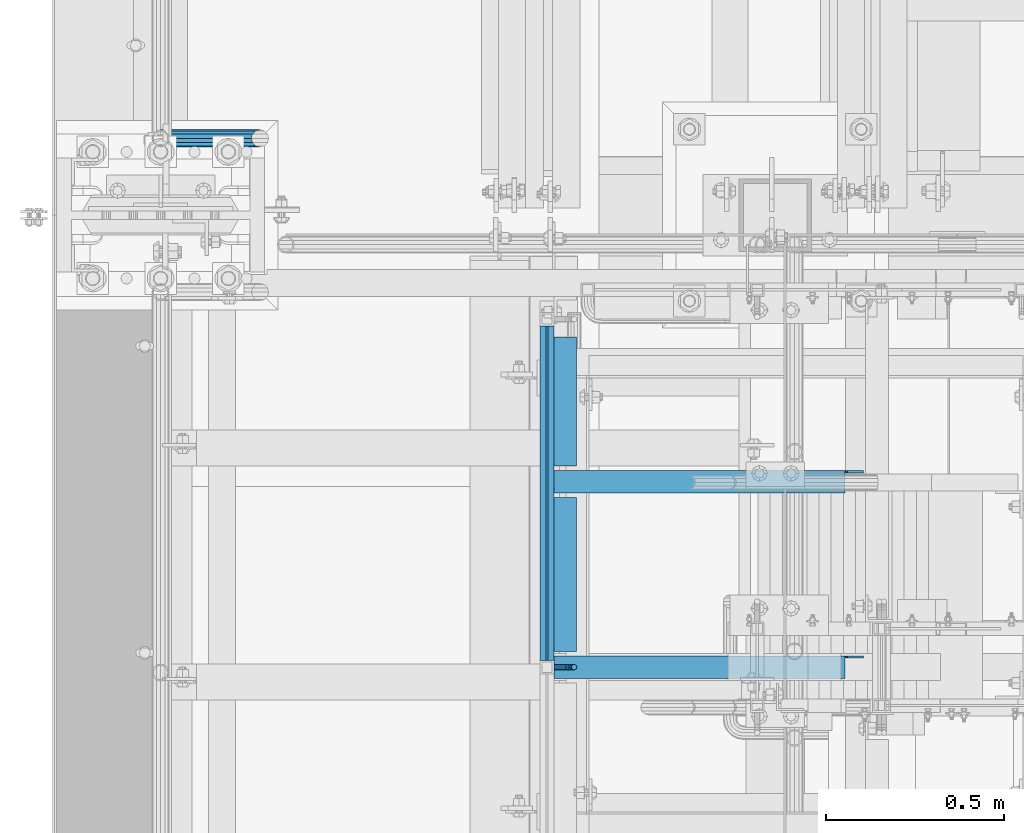
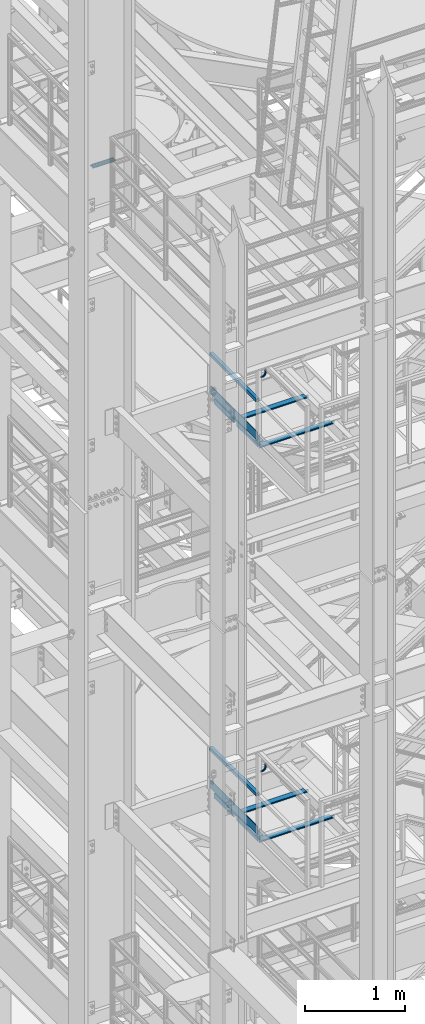
# One storey, part 1157 of 1876: 15 beams, 5 elements without a shape of their own.
"""IFC2X3 building model written with IfcOpenShell, lengths in millimetres."""

from ifc_helpers import new_model, si_unit, frame, origin_with_axes, place, context, subcontext, project, spatial, faceted_brep, material, type_object, element, aggregate, save


model = new_model("IFC2X3")

# Units and contexts
model_context = context("Model", 3, precision=1e-05, world=origin_with_axes())
body_context = subcontext(model_context, "Body", "Model", "MODEL_VIEW")
ifc_project = project(units=[si_unit("LENGTHUNIT", "METRE", prefix="MILLI"), si_unit("AREAUNIT", "SQUARE_METRE"), si_unit("VOLUMEUNIT", "CUBIC_METRE"), si_unit("MASSUNIT", "GRAM", prefix="KILO"), si_unit("TIMEUNIT", "SECOND"), si_unit("PLANEANGLEUNIT", "RADIAN"), si_unit("SOLIDANGLEUNIT", "STERADIAN"), si_unit("THERMODYNAMICTEMPERATUREUNIT", "DEGREE_CELSIUS"), si_unit("LUMINOUSINTENSITYUNIT", "LUMEN")], contexts=[model_context])

# Site, building, storey
site_placement = place(None, origin_with_axes())
site = spatial("IfcSite", under=ifc_project, at=site_placement, CompositionType="ELEMENT")
building_placement = place(site_placement, origin_with_axes())
building = spatial("IfcBuilding", under=site, at=building_placement, Name="Undefined", CompositionType="ELEMENT")
storey_placement = place(building_placement, origin_with_axes())
storey = spatial("IfcBuildingStorey", under=building, at=storey_placement, Name="Undefined", CompositionType="ELEMENT", Elevation=0.0)

# Assembly, beam
assembly_1_placement = place(storey_placement, origin_with_axes())
assembly_1 = element("IfcElementAssembly", 1, at=assembly_1_placement, inside=storey, Name="RAIL", AssemblyPlace="NOTDEFINED", PredefinedType="RIGID_FRAME")
ifc_material_1 = material()
beam_type_1 = type_object("IfcBeamType", Name="PIPE1-1/2SCH40", PredefinedType="NOTDEFINED")
beam_1_placement = place(assembly_1_placement, frame((-1.00044417195022e-11, -4356.1, 18449.925000036), z_axis=(0.0, 0.0, 1.0), x_axis=(1.0, 0.0, 0.0)))
beam_1 = element("IfcBeam", 2, at=beam_1_placement, type_object=beam_type_1, material=ifc_material_1, Name="RAIL", ObjectType="PIPE1-1/2SCH40", context=body_context, shape_type="Brep", body=[
    faceted_brep([(258.502800903171, -12.0650000000005, 20.8971929933177), (258.502800903171, -12.0650000000005, 15.8661214311796), (258.009372465309, -10.2235000000001, 17.7076214311819), (255.26999389649, 0.0, 20.4470000000001), (255.26999389649, 0.0, 24.130000000001), (258.009372465309, 10.2235000000001, 17.7076214311819), (258.502800903171, 12.0650000000005, 15.8661214311796), (258.502800903171, 12.0650000000005, 20.8971929933177), (279.399993896489, 24.1299999999992, 0.0), (267.33499389649, 20.8971929933177, 12.0649999999987), (267.33499389649, 20.8971929933177, -12.0649999999987), (264.145422334351, 17.7076214311801, 10.2235000000001), (266.884800903171, 20.4470000000001, 0.0), (264.145422334351, 17.7076214311801, -10.2235000000001), (258.502800903171, 12.0650000000005, -15.8661214311796), (258.502800903171, 12.0650000000005, -20.8971929933177), (258.009372465309, 10.2235000000001, -17.7076214311819), (255.26999389649, 0.0, -20.4470000000001), (255.26999389649, 0.0, -24.130000000001), (258.502800903171, -12.0650000000005, -15.8661214311796), (258.502800903171, -12.0650000000005, -20.8971929933177), (258.009372465309, -10.2235000000001, -17.7076214311819), (279.399993896489, -24.1299999999992, 0.0), (267.33499389649, -20.8971929933177, -12.0649999999987), (267.33499389649, -20.8971929933177, 12.0649999999987), (264.145422334351, -17.7076214311801, -10.2235000000001), (266.884800903171, -20.4470000000001, 0.0), (264.145422334351, -17.7076214311801, 10.2235000000001), (12.0650000000064, -20.8971929933177, -12.0649999999987), (20.8971929933249, -12.0650000000005, -20.8971929933177), (0.0, 24.1299999999992, 0.0), (12.0650000000064, 20.8971929933177, -12.0649999999987), (12.0650000000064, 20.8971929933177, 12.0649999999987), (20.8971929933249, 12.0650000000005, 20.8971929933177), (24.1300000000064, 0.0, 24.130000000001), (20.8971929933249, 12.0650000000005, -20.8971929933177), (24.1300000000063, 0.0, -24.130000000001), (24.1300000000063, 0.0, -20.4470000000001), (20.8971929933249, -12.0650000000005, -15.8661214311796), (21.3906214311868, -10.2235000000001, -17.7076214311819), (21.3906214311868, 10.2235000000001, -17.7076214311819), (20.8971929933249, 12.0650000000005, -15.8661214311796), (15.2545715621445, 17.7076214311801, -10.2235000000001), (12.5151929933249, 20.4470000000001, 0.0), (15.2545715621445, 17.7076214311801, 10.2235000000001), (20.8971929933249, 12.0650000000005, 15.8661214311796), (21.3906214311868, 10.2235000000001, 17.7076214311819), (24.1300000000064, 0.0, 20.4470000000001), (21.3906214311868, -10.2235000000001, 17.7076214311819), (20.8971929933249, -12.0650000000005, 15.8661214311796), (20.8971929933249, -12.0650000000005, 20.8971929933177), (12.0650000000064, -20.8971929933177, 12.0649999999987), (0.0, -24.1299999999992, 0.0), (15.2545715621445, -17.7076214311801, 10.2235000000001), (12.5151929933249, -20.4470000000001, 0.0), (15.2545715621445, -17.7076214311801, -10.2235000000001)], [[[0, 1, 2, 3, 4]], [[4, 3, 5, 6, 7]], [[8, 9, 10]], [[7, 6, 11, 12, 13, 14, 15, 10, 9]], [[16, 17, 18, 15, 14]], [[19, 20, 18, 17, 21]], [[22, 23, 24]], [[24, 23, 20, 19, 25, 26, 27, 1, 0]], [[28, 29, 20, 23]], [[30, 31, 32]], [[33, 34, 4, 7]], [[32, 33, 7, 9]], [[30, 32, 9, 8]], [[31, 30, 8, 10]], [[35, 31, 10, 15]], [[36, 35, 15, 18]], [[29, 36, 18, 20]], [[37, 36, 29, 38, 39]], [[40, 41, 35, 36, 37]], [[32, 31, 35, 41, 42, 43, 44, 45, 33]], [[33, 45, 46, 47, 34]], [[34, 47, 48, 49, 50]], [[34, 50, 0, 4]], [[50, 51, 24, 0]], [[51, 52, 22, 24]], [[52, 28, 23, 22]], [[51, 28, 52]], [[50, 49, 53, 54, 55, 38, 29, 28, 51]], [[55, 54, 26, 25]], [[21, 39, 38, 55, 25, 19]], [[37, 39, 21, 17]], [[40, 37, 17, 16]], [[42, 41, 40, 16, 14, 13]], [[43, 42, 13, 12]], [[44, 43, 12, 11]], [[5, 46, 45, 44, 11, 6]], [[47, 46, 5, 3]], [[48, 47, 3, 2]], [[53, 49, 48, 2, 1, 27]], [[54, 53, 27, 26]]]),
])
aggregate(assembly_1, [beam_1])

# Assembly, beams
assembly_2_placement = place(storey_placement, origin_with_axes())
assembly_2 = element("IfcElementAssembly", 3, at=assembly_2_placement, inside=storey, Name="STRINGER", AssemblyPlace="NOTDEFINED", PredefinedType="RIGID_FRAME")
ifc_material_2 = material(Name="STEEL/A36")
beam_type_2 = type_object("IfcBeamType", Name="L2-1/2X2-1/2X1/4", PredefinedType="NOTDEFINED")
beam_2_placement = place(assembly_2_placement, frame((1136.65000017493, -5797.55000149109, 15531.2768517499), z_axis=(1.0, 0.0, 0.0), x_axis=(0.0, 1.0, 0.0)))
beam_2 = element("IfcBeam", 4, at=beam_2_placement, type_object=beam_type_2, material=ifc_material_2, Name="ANGLE", ObjectType="L2-1/2X2-1/2X1/4", context=body_context, shape_type="Brep", body=[
    faceted_brep([(0.0, 31.75, -31.75), (0.0, 31.75, 31.75), (431.800000762049, 31.75, 31.75), (431.800000762049, 31.75, -31.75), (0.0, 25.3999999999996, 31.75), (431.800000762049, 25.3999999999996, 31.75), (0.0, 25.3999999999996, -25.3999999999996), (431.800000762049, 25.3999999999996, -25.4000000000001), (0.0, -31.75, -25.3999999999996), (431.800000762049, -31.75, -25.4000000000001), (0.0, -31.75, -31.75), (431.800000762049, -31.75, -31.75)], [[[0, 1, 2, 3]], [[1, 4, 5, 2]], [[4, 6, 7, 5]], [[6, 8, 9, 7]], [[8, 10, 11, 9]], [[10, 0, 3, 11]], [[5, 7, 9, 11, 3, 2]], [[10, 8, 6, 4, 1, 0]]]),
])
beam_3_placement = place(assembly_2_placement, frame((1136.64999999374, -5276.85000132472, 15531.2768517499), z_axis=(1.0, 0.0, 0.0), x_axis=(0.0, 1.0, 0.0)))
beam_3 = element("IfcBeam", 5, at=beam_3_placement, type_object=beam_type_2, material=ifc_material_2, Name="ANGLE", ObjectType="L2-1/2X2-1/2X1/4", context=body_context, shape_type="Brep", body=[
    faceted_brep([(0.0, 31.75, -31.75), (0.0, 31.75, 31.75), (361.950002661927, 31.75, 31.7499999999923), (361.950002661926, 31.75, -31.7500000000077), (0.0, 25.3999999999996, 31.75), (361.950002661927, 25.3999999999996, 31.7499999999923), (0.0, 25.3999999999996, -25.3999999999996), (361.950002661926, 25.3999999999996, -25.4000000000076), (0.0, -31.75, -25.3999999999996), (361.950002661926, -31.75, -25.4000000000076), (0.0, -31.75, -31.75), (361.950002661926, -31.75, -31.7500000000077)], [[[0, 1, 2, 3]], [[1, 4, 5, 2]], [[4, 6, 7, 5]], [[6, 8, 9, 7]], [[8, 10, 11, 9]], [[10, 0, 3, 11]], [[5, 7, 9, 11, 3, 2]], [[10, 8, 6, 4, 1, 0]]]),
])

assembly_3_placement = place(storey_placement, origin_with_axes())
assembly_3 = element("IfcElementAssembly", 6, at=assembly_3_placement, inside=storey, Name="STRINGER", AssemblyPlace="NOTDEFINED", PredefinedType="RIGID_FRAME")
beam_4_placement = place(assembly_3_placement, frame((1136.65000052344, -5797.55000149059, 10702.925), z_axis=(1.0, 0.0, 0.0), x_axis=(0.0, 1.0, 0.0)))
beam_4 = element("IfcBeam", 7, at=beam_4_placement, type_object=beam_type_2, material=ifc_material_2, Name="ANGLE", ObjectType="L2-1/2X2-1/2X1/4", context=body_context, shape_type="Brep", body=[
    faceted_brep([(0.0, 31.75, -31.75), (0.0, 31.75, 31.75), (431.800000762049, 31.75, 31.75), (431.800000762049, 31.75, -31.75), (0.0, 25.3999999999996, 31.75), (431.800000762049, 25.3999999999996, 31.75), (0.0, 25.3999999999996, -25.3999999999996), (431.800000762049, 25.3999999999996, -25.4000000000001), (0.0, -31.75, -25.3999999999996), (431.800000762049, -31.75, -25.4000000000001), (0.0, -31.75, -31.75), (431.800000762049, -31.75, -31.75)], [[[0, 1, 2, 3]], [[1, 4, 5, 2]], [[4, 6, 7, 5]], [[6, 8, 9, 7]], [[8, 10, 11, 9]], [[10, 0, 3, 11]], [[5, 7, 9, 11, 3, 2]], [[10, 8, 6, 4, 1, 0]]]),
])
beam_5_placement = place(assembly_3_placement, frame((1136.65000034225, -5276.85000132422, 10702.925), z_axis=(1.0, 0.0, 0.0), x_axis=(0.0, 1.0, 0.0)))
beam_5 = element("IfcBeam", 8, at=beam_5_placement, type_object=beam_type_2, material=ifc_material_2, Name="ANGLE", ObjectType="L2-1/2X2-1/2X1/4", context=body_context, shape_type="Brep", body=[
    faceted_brep([(0.0, 31.75, -31.75), (0.0, 31.75, 31.75), (361.950002661927, 31.75, 31.7499999999923), (361.950002661926, 31.75, -31.7500000000077), (0.0, 25.3999999999996, 31.75), (361.950002661927, 25.3999999999996, 31.7499999999923), (0.0, 25.3999999999996, -25.3999999999996), (361.950002661926, 25.3999999999996, -25.4000000000076), (0.0, -31.75, -25.3999999999996), (361.950002661926, -31.75, -25.4000000000076), (0.0, -31.75, -31.75), (361.950002661926, -31.75, -31.7500000000077)], [[[0, 1, 2, 3]], [[1, 4, 5, 2]], [[4, 6, 7, 5]], [[6, 8, 9, 7]], [[8, 10, 11, 9]], [[10, 0, 3, 11]], [[5, 7, 9, 11, 3, 2]], [[10, 8, 6, 4, 1, 0]]]),
])

# Beam
beam_6_placement = place(assembly_2_placement, frame((1104.90000017493, -5842.0000011457, 15531.3367794488), z_axis=(0.0, -1.0, 0.0), x_axis=(1.0, 0.0, 0.0)))
beam_6 = element("IfcBeam", 9, at=beam_6_placement, type_object=beam_type_2, material=ifc_material_2, Name="STRINGER", ObjectType="L2-1/2X2-1/2X1/4", context=body_context, shape_type="Brep", body=[
    faceted_brep([(0.0, -31.75, -31.75), (0.0, -31.75, -25.3999999999996), (0.0, 25.3999999999996, -25.3999999999996), (0.0, 25.3999999999996, 31.75), (0.0, 31.75, 31.75), (0.0, 31.75, -31.75), (869.950004852295, 6.34999909336329, -25.3999999999996), (830.262999809266, 6.34999909336329, -25.3999999999996), (825.40292029122, 7.31672901595084, -25.3999999999996), (821.282743823066, 10.0697429164284, -25.3999999999996), (818.529729922588, 14.189919384582, -25.3999999999996), (817.563000000001, 19.0499989026284, -25.3999999999996), (817.563000000001, 25.3999999999996, -25.3999999999996), (869.949999999999, -31.75, -25.3999999999996), (869.950004852295, -19.0499986178183, -25.3999999999996), (817.563000000001, 25.3999999999996, 31.75), (817.563000000001, 31.75, 31.75), (817.563000000001, 31.75, -31.75), (817.563000000001, 19.0499989026284, -31.75), (818.529729922588, 14.189919384582, -31.75), (821.282743823066, 10.0697429164284, -31.75), (825.40292029122, 7.31672901595084, -31.75), (830.262999809266, 6.34999909336329, -31.75), (869.950004852295, 6.34999909336329, -31.75), (869.950004852295, -19.0499986178183, -31.75), (869.949999999999, -31.75, -31.75)], [[[0, 1, 2, 3, 4, 5]], [[6, 7, 8, 9, 10, 11, 12, 2, 1, 13, 14]], [[3, 2, 12, 15]], [[4, 3, 15, 16]], [[5, 4, 16, 17]], [[15, 12, 11, 18, 17, 16]], [[10, 19, 18, 11]], [[9, 20, 19, 10]], [[8, 21, 20, 9]], [[7, 22, 21, 8]], [[6, 23, 22, 7]], [[14, 24, 23, 6]], [[0, 5, 17, 18, 19, 20, 21, 22, 23, 24, 25]], [[1, 0, 25, 13]], [[24, 14, 13, 25]]]),
])

beam_7_placement = place(assembly_2_placement, frame((1104.89999999374, -5321.30000114659, 15531.3367793052), z_axis=(0.0, -1.0, 0.0), x_axis=(1.0, 0.0, 0.0)))
beam_7 = element("IfcBeam", 10, at=beam_7_placement, type_object=beam_type_2, material=ifc_material_2, Name="STRINGER", ObjectType="L2-1/2X2-1/2X1/4", context=body_context, shape_type="Brep", body=[
    faceted_brep([(0.0, -31.75, -31.75), (0.0, -31.75, -25.3999999999996), (0.0, 25.3999999999996, -25.3999999999996), (0.0, 25.3999999999996, 31.75), (0.0, 31.75, 31.75), (0.0, 31.75, -31.75), (869.950004852295, 6.34999909336329, -25.3999999999996), (830.262999809266, 6.34999909336329, -25.3999999999996), (825.40292029122, 7.31672901595084, -25.3999999999996), (821.282743823066, 10.0697429164284, -25.3999999999996), (818.529729922588, 14.189919384582, -25.3999999999996), (817.563000000001, 19.0499989026284, -25.3999999999996), (817.563000000001, 25.3999999999996, -25.3999999999996), (869.949999999999, -31.75, -25.3999999999996), (869.950004852295, -19.0499986178183, -25.3999999999996), (817.563000000001, 25.3999999999996, 31.75), (817.563000000001, 31.75, 31.75), (817.563000000001, 31.75, -31.75), (817.563000000001, 19.0499989026284, -31.75), (818.529729922588, 14.189919384582, -31.75), (821.282743823066, 10.0697429164284, -31.75), (825.40292029122, 7.31672901595084, -31.75), (830.262999809266, 6.34999909336329, -31.75), (869.950004852295, 6.34999909336329, -31.75), (869.950004852295, -19.0499986178183, -31.75), (869.949999999999, -31.75, -31.75)], [[[0, 1, 2, 3, 4, 5]], [[6, 7, 8, 9, 10, 11, 12, 2, 1, 13, 14]], [[3, 2, 12, 15]], [[4, 3, 15, 16]], [[5, 4, 16, 17]], [[15, 12, 11, 18, 17, 16]], [[10, 19, 18, 11]], [[9, 20, 19, 10]], [[8, 21, 20, 9]], [[7, 22, 21, 8]], [[6, 23, 22, 7]], [[14, 24, 23, 6]], [[0, 5, 17, 18, 19, 20, 21, 22, 23, 24, 25]], [[1, 0, 25, 13]], [[24, 14, 13, 25]]]),
])

aggregate(assembly_2, [beam_2, beam_3, beam_6, beam_7])

beam_8_placement = place(assembly_3_placement, frame((1104.90000052344, -5842.00000114519, 10702.9250002874), z_axis=(0.0, -1.0, 0.0), x_axis=(1.0, 0.0, 0.0)))
beam_8 = element("IfcBeam", 11, at=beam_8_placement, type_object=beam_type_2, material=ifc_material_2, Name="STRINGER", ObjectType="L2-1/2X2-1/2X1/4", context=body_context, shape_type="Brep", body=[
    faceted_brep([(0.0, -31.75, -31.75), (0.0, -31.75, -25.3999999999996), (0.0, 25.3999999999996, -25.3999999999996), (0.0, 25.3999999999996, 31.75), (0.0, 31.75, 31.75), (0.0, 31.75, -31.75), (869.950004852295, 6.34999909336329, -25.3999999999996), (830.262999809266, 6.34999909336329, -25.3999999999996), (825.40292029122, 7.31672901595084, -25.3999999999996), (821.282743823066, 10.0697429164284, -25.3999999999996), (818.529729922588, 14.189919384582, -25.3999999999996), (817.563000000001, 19.0499989026284, -25.3999999999996), (817.563000000001, 25.3999999999996, -25.3999999999996), (869.949999999999, -31.75, -25.3999999999996), (869.950004852295, -19.0499986178183, -25.3999999999996), (817.563000000001, 25.3999999999996, 31.75), (817.563000000001, 31.75, 31.75), (817.563000000001, 31.75, -31.75), (817.563000000001, 19.0499989026284, -31.75), (818.529729922588, 14.189919384582, -31.75), (821.282743823066, 10.0697429164284, -31.75), (825.40292029122, 7.31672901595084, -31.75), (830.262999809266, 6.34999909336329, -31.75), (869.950004852295, 6.34999909336329, -31.75), (869.950004852295, -19.0499986178183, -31.75), (869.949999999999, -31.75, -31.75)], [[[0, 1, 2, 3, 4, 5]], [[6, 7, 8, 9, 10, 11, 12, 2, 1, 13, 14]], [[3, 2, 12, 15]], [[4, 3, 15, 16]], [[5, 4, 16, 17]], [[15, 12, 11, 18, 17, 16]], [[10, 19, 18, 11]], [[9, 20, 19, 10]], [[8, 21, 20, 9]], [[7, 22, 21, 8]], [[6, 23, 22, 7]], [[14, 24, 23, 6]], [[0, 5, 17, 18, 19, 20, 21, 22, 23, 24, 25]], [[1, 0, 25, 13]], [[24, 14, 13, 25]]]),
])

beam_9_placement = place(assembly_3_placement, frame((1104.90000034225, -5321.30000114608, 10702.9250001437), z_axis=(0.0, -1.0, 0.0), x_axis=(1.0, 0.0, 0.0)))
beam_9 = element("IfcBeam", 12, at=beam_9_placement, type_object=beam_type_2, material=ifc_material_2, Name="STRINGER", ObjectType="L2-1/2X2-1/2X1/4", context=body_context, shape_type="Brep", body=[
    faceted_brep([(0.0, -31.75, -31.75), (0.0, -31.75, -25.3999999999996), (0.0, 25.3999999999996, -25.3999999999996), (0.0, 25.3999999999996, 31.75), (0.0, 31.75, 31.75), (0.0, 31.75, -31.75), (869.950004852295, 6.34999909336329, -25.3999999999996), (830.262999809266, 6.34999909336329, -25.3999999999996), (825.40292029122, 7.31672901595084, -25.3999999999996), (821.282743823066, 10.0697429164284, -25.3999999999996), (818.529729922588, 14.189919384582, -25.3999999999996), (817.563000000001, 19.0499989026284, -25.3999999999996), (817.563000000001, 25.3999999999996, -25.3999999999996), (869.949999999999, -31.75, -25.3999999999996), (869.950004852295, -19.0499986178183, -25.3999999999996), (817.563000000001, 25.3999999999996, 31.75), (817.563000000001, 31.75, 31.75), (817.563000000001, 31.75, -31.75), (817.563000000001, 19.0499989026284, -31.75), (818.529729922588, 14.189919384582, -31.75), (821.282743823066, 10.0697429164284, -31.75), (825.40292029122, 7.31672901595084, -31.75), (830.262999809266, 6.34999909336329, -31.75), (869.950004852295, 6.34999909336329, -31.75), (869.950004852295, -19.0499986178183, -31.75), (869.949999999999, -31.75, -31.75)], [[[0, 1, 2, 3, 4, 5]], [[6, 7, 8, 9, 10, 11, 12, 2, 1, 13, 14]], [[3, 2, 12, 15]], [[4, 3, 15, 16]], [[5, 4, 16, 17]], [[15, 12, 11, 18, 17, 16]], [[10, 19, 18, 11]], [[9, 20, 19, 10]], [[8, 21, 20, 9]], [[7, 22, 21, 8]], [[6, 23, 22, 7]], [[14, 24, 23, 6]], [[0, 5, 17, 18, 19, 20, 21, 22, 23, 24, 25]], [[1, 0, 25, 13]], [[24, 14, 13, 25]]]),
])

aggregate(assembly_3, [beam_4, beam_5, beam_8, beam_9])

# Assembly, beam
assembly_4_placement = place(storey_placement, origin_with_axes())
assembly_4 = element("IfcElementAssembly", 13, at=assembly_4_placement, inside=storey, Name="RAIL", AssemblyPlace="NOTDEFINED", PredefinedType="RIGID_FRAME")
beam_type_3 = type_object("IfcBeamType", PredefinedType="NOTDEFINED")
beam_10_placement = place(assembly_4_placement, frame((1085.85000037624, -5842.000001149, 15658.2768517481), z_axis=(0.0, 0.0, 1.0), x_axis=(0.0, 1.0, 0.0)))
beam_10 = element("IfcBeam", 14, at=beam_10_placement, type_object=beam_type_3, material=ifc_material_2, Name="PLATE", context=body_context, shape_type="Brep", body=[
    faceted_brep([(19.049997819523, 3.17500000000018, -50.7999999999975), (19.049997413123, 3.17500000000018, 50.8000000000011), (958.85000076813, 3.17499999999995, 50.7999999999993), (958.85000076813, 3.17499999999995, -50.7999999999993), (19.049997413123, -3.17500000000018, 50.8000000000011), (958.85000076813, -3.17499999999995, 50.7999999999993), (19.049997819523, -3.17500000000018, -50.7999999999975), (958.85000076813, -3.17499999999995, -50.7999999999993)], [[[0, 1, 2, 3]], [[1, 4, 5, 2]], [[4, 6, 7, 5]], [[6, 0, 3, 7]], [[5, 7, 3, 2]], [[6, 4, 1, 0]]]),
])

# Assembly, beams
assembly_5_placement = place(storey_placement, origin_with_axes())
assembly_5 = element("IfcElementAssembly", 15, at=assembly_5_placement, inside=storey, Name="RAIL", AssemblyPlace="NOTDEFINED", PredefinedType="RIGID_FRAME")
beam_11_placement = place(assembly_5_placement, frame((1085.85000225475, -5842.00000114849, 10829.9249999981), z_axis=(0.0, 0.0, 1.0), x_axis=(0.0, 1.0, 0.0)))
beam_11 = element("IfcBeam", 16, at=beam_11_placement, type_object=beam_type_3, material=ifc_material_2, Name="PLATE", context=body_context, shape_type="Brep", body=[
    faceted_brep([(19.049997819523, 3.17500000000018, -50.7999999999975), (19.049997413123, 3.17500000000018, 50.8000000000011), (958.85000076813, 3.17499999999995, 50.7999999999993), (958.85000076813, 3.17499999999995, -50.7999999999993), (19.049997413123, -3.17500000000018, 50.8000000000011), (958.85000076813, -3.17499999999995, 50.7999999999993), (19.049997819523, -3.17500000000018, -50.7999999999975), (958.85000076813, -3.17499999999995, -50.7999999999993)], [[[0, 1, 2, 3]], [[1, 4, 5, 2]], [[4, 6, 7, 5]], [[6, 0, 3, 7]], [[5, 7, 3, 2]], [[6, 4, 1, 0]]]),
])
ifc_material_3 = material()
beam_type_4 = type_object("IfcBeamType", Name="HSS1-1/2X1-1/2X1/8", PredefinedType="NOTDEFINED")
beam_12_placement = place(assembly_5_placement, frame((1085.85000034225, -4864.10000114536, 11274.4249999981), z_axis=(0.0, 0.0, 1.0), x_axis=(0.0, -1.0, 0.0)))
beam_12 = element("IfcBeam", 17, at=beam_12_placement, type_object=beam_type_4, material=ifc_material_3, Name="RAIL", ObjectType="HSS1-1/2X1-1/2X1/8", context=body_context, shape_type="Brep", body=[
    faceted_brep([(958.850000766446, -19.0499992350001, 19.0499992349996), (958.850000766446, -19.0499992350001, -19.0499992349996), (958.850000766446, 19.0499992350001, -19.0499992349996), (958.850000766446, 19.0499992350001, 19.0499992349996), (958.850000766446, -15.8749992830001, 15.8749992829999), (958.850000766446, 15.8749992830001, 15.8749992829999), (958.850000766446, 15.8749992830001, -15.8749992829999), (958.850000766446, -15.8749992830001, -15.8749992829999), (19.0500000000002, 19.0499992349996, 19.0499992350001), (19.0500000000002, -19.0499992349996, 19.0499992350001), (19.0500000000002, -19.0499992349996, -19.0499992350001), (19.0500000000002, 19.0499992349996, -19.0499992350001), (19.0500000000002, -15.8749992829999, 15.8749992829999), (19.0500000000002, -15.8749992829999, -15.8749992829999), (19.0500000000002, 15.8749992829999, -15.8749992829999), (19.0500000000002, 15.8749992829999, 15.8749992829999)], [[[0, 1, 2, 3], [4, 5, 6, 7]], [[0, 3, 8, 9]], [[2, 1, 10, 11]], [[1, 0, 9, 10]], [[3, 2, 11, 8]], [[9, 8, 11, 10], [12, 13, 14, 15]], [[4, 7, 13, 12]], [[7, 6, 14, 13]], [[6, 5, 15, 14]], [[5, 4, 12, 15]]]),
])

# Beam
beam_13_placement = place(assembly_4_placement, frame((1085.84999999374, -4864.10000114587, 16102.776851748), z_axis=(0.0, 0.0, 1.0), x_axis=(0.0, -1.0, 0.0)))
beam_13 = element("IfcBeam", 18, at=beam_13_placement, type_object=beam_type_4, material=ifc_material_3, Name="RAIL", ObjectType="HSS1-1/2X1-1/2X1/8", context=body_context, shape_type="Brep", body=[
    faceted_brep([(958.850000766446, -19.0499992350001, 19.0499992349996), (958.850000766446, -19.0499992350001, -19.0499992349996), (958.850000766446, 19.0499992350001, -19.0499992349996), (958.850000766446, 19.0499992350001, 19.0499992349996), (958.850000766446, -15.8749992830001, 15.8749992829999), (958.850000766446, 15.8749992830001, 15.8749992829999), (958.850000766446, 15.8749992830001, -15.8749992829999), (958.850000766446, -15.8749992830001, -15.8749992829999), (19.0500000000002, 19.0499992349996, 19.0499992350001), (19.0500000000002, -19.0499992349996, 19.0499992350001), (19.0500000000002, -19.0499992349996, -19.0499992350001), (19.0500000000002, 19.0499992349996, -19.0499992350001), (19.0500000000002, -15.8749992829999, 15.8749992829999), (19.0500000000002, -15.8749992829999, -15.8749992829999), (19.0500000000002, 15.8749992829999, -15.8749992829999), (19.0500000000002, 15.8749992829999, 15.8749992829999)], [[[0, 1, 2, 3], [4, 5, 6, 7]], [[0, 3, 8, 9]], [[2, 1, 10, 11]], [[1, 0, 9, 10]], [[3, 2, 11, 8]], [[9, 8, 11, 10], [12, 13, 14, 15]], [[4, 7, 13, 12]], [[7, 6, 14, 13]], [[6, 5, 15, 14]], [[5, 4, 12, 15]]]),
])

beam_type_5 = type_object("IfcBeamType", PredefinedType="NOTDEFINED")
beam_14_placement = place(assembly_4_placement, frame((1104.89999922875, -5842.00000191232, 16388.4316082526), z_axis=(0.0, -1.0, 0.0), x_axis=(1.0, 0.0, 0.0)))
beam_14 = element("IfcBeam", 19, at=beam_14_placement, type_object=beam_type_5, material=ifc_material_2, Name="BRACKET", context=body_context, shape_type="Brep", body=[
    faceted_brep([(0.0, -7.9375, 0.0), (0.0, -5.61266007566822, -5.61266007566883), (23.8125, -5.61266007566883, -5.61266007566792), (23.8125, -7.9375, 0.0), (0.0, 0.0, -7.9375), (23.8125, 0.0, -7.9375), (0.0, 5.61266007566822, -5.61266007566883), (23.8125, 5.61266007566883, -5.61266007566792), (0.0, 7.9375, 0.0), (23.8125, 7.9375, 0.0), (0.0, 5.61266007566822, 5.61266007566883), (23.8125, 5.61266007566883, 5.61266007566792), (0.0, 0.0, 7.9375), (23.8125, 0.0, 7.9375), (0.0, -5.61266007566822, 5.61266007566883), (23.8125, -5.61266007566883, 5.61266007566792), (39.6077592547981, -4.79562758825341, 0.0), (38.7180815328556, -2.64775556579843, 5.61266007566792), (36.5702095103998, 2.53766620105671, 7.9375), (34.4223374879448, 7.72308796790821, 5.61266007566792), (33.5326597660023, 9.87095999036319, 0.0), (34.4223374879448, 7.72308796790821, -5.61266007566792), (36.5702095103998, 2.53766620105671, -7.9375), (38.7180815328556, -2.64775556579843, -5.61266007566792), (51.3544233967659, 5.79557812911298, -5.61266007566792), (52.9983334724348, 4.15166805344415, 0.0), (47.3856733967659, 9.76432812911298, -7.9375), (43.4169233967659, 13.733078129113, -5.61266007566792), (41.773013321098, 15.3769882047818, 0.0), (43.4169233967659, 13.733078129113, 5.61266007566792), (47.3856733967659, 9.76432812911298, 7.9375), (51.3544233967659, 5.79557812911298, 5.61266007566792), (59.7977570916764, 18.4319199930251, -5.61266007566792), (61.9456291141314, 17.5422422710835, 0.0), (54.6123353248231, 20.5797920154801, -7.9375), (49.4269135579698, 22.727664037935, -5.61266007566792), (47.2790415355148, 23.6173417598766, 0.0), (49.4269135579698, 22.727664037935, 5.61266007566792), (54.6123353248231, 20.5797920154801, 7.9375), (59.7977570916764, 18.4319199930251, 5.61266007566792), (62.7626616015468, 33.3375015258789, -5.61266007566792), (65.0875015258789, 33.3375015258789, 0.0), (57.1500015258789, 33.3375015258789, -7.9375), (51.5373414502101, 33.3375015258789, -5.61266007566792), (49.2125015258789, 33.3375015258789, 0.0), (51.5373414502101, 33.3375015258789, 5.61266007566792), (57.1500015258789, 33.3375015258789, 7.9375), (62.7626616015468, 33.3375015258789, 5.61266007566792), (62.7626616015468, 76.1999969482422, -5.61266007566792), (65.0875015258789, 76.1999969482422, 0.0), (57.1500015258789, 76.1999969482422, -7.9375), (51.537341450211, 76.1999969482422, -5.61266007566792), (49.2125015258789, 76.1999969482422, 0.0), (51.537341450211, 76.1999969482422, 5.61266007566792), (57.1500015258789, 76.1999969482422, 7.9375), (62.7626616015468, 76.1999969482422, 5.61266007566792)], [[[0, 1, 2, 3]], [[1, 4, 5, 2]], [[4, 6, 7, 5]], [[6, 8, 9, 7]], [[8, 10, 11, 9]], [[10, 12, 13, 11]], [[12, 14, 15, 13]], [[14, 0, 3, 15]], [[14, 12, 10, 8, 6, 4, 1, 0]], [[15, 3, 16, 17]], [[13, 15, 17, 18]], [[11, 13, 18, 19]], [[9, 11, 19, 20]], [[7, 9, 20, 21]], [[5, 7, 21, 22]], [[2, 5, 22, 23]], [[3, 2, 23, 16]], [[23, 24, 25, 16]], [[22, 26, 24, 23]], [[21, 27, 26, 22]], [[20, 28, 27, 21]], [[19, 29, 28, 20]], [[18, 30, 29, 19]], [[17, 31, 30, 18]], [[16, 25, 31, 17]], [[24, 32, 33, 25]], [[26, 34, 32, 24]], [[27, 35, 34, 26]], [[28, 36, 35, 27]], [[29, 37, 36, 28]], [[30, 38, 37, 29]], [[31, 39, 38, 30]], [[25, 33, 39, 31]], [[32, 40, 41, 33]], [[34, 42, 40, 32]], [[35, 43, 42, 34]], [[36, 44, 43, 35]], [[37, 45, 44, 36]], [[38, 46, 45, 37]], [[39, 47, 46, 38]], [[33, 41, 47, 39]], [[41, 40, 48, 49]], [[40, 42, 50, 48]], [[42, 43, 51, 50]], [[43, 44, 52, 51]], [[44, 45, 53, 52]], [[45, 46, 54, 53]], [[46, 47, 55, 54]], [[47, 41, 49, 55]], [[50, 51, 52, 53, 54, 55, 49, 48]]]),
])

aggregate(assembly_4, [beam_14, beam_10, beam_13])

beam_15_placement = place(assembly_5_placement, frame((1104.89999957726, -5842.00000191181, 11560.0797565027), z_axis=(0.0, -1.0, 0.0), x_axis=(1.0, 0.0, 0.0)))
beam_15 = element("IfcBeam", 20, at=beam_15_placement, type_object=beam_type_5, material=ifc_material_2, Name="BRACKET", context=body_context, shape_type="Brep", body=[
    faceted_brep([(0.0, -7.9375, 0.0), (0.0, -5.61266007566822, -5.61266007566883), (23.8125, -5.61266007566883, -5.61266007566792), (23.8125, -7.9375, 0.0), (0.0, 0.0, -7.9375), (23.8125, 0.0, -7.9375), (0.0, 5.61266007566822, -5.61266007566883), (23.8125, 5.61266007566883, -5.61266007566792), (0.0, 7.9375, 0.0), (23.8125, 7.9375, 0.0), (0.0, 5.61266007566822, 5.61266007566883), (23.8125, 5.61266007566883, 5.61266007566792), (0.0, 0.0, 7.9375), (23.8125, 0.0, 7.9375), (0.0, -5.61266007566822, 5.61266007566883), (23.8125, -5.61266007566883, 5.61266007566792), (39.6077592547981, -4.79562758825341, 0.0), (38.7180815328556, -2.64775556579843, 5.61266007566792), (36.5702095103998, 2.53766620105671, 7.9375), (34.4223374879448, 7.72308796790821, 5.61266007566792), (33.5326597660023, 9.87095999036319, 0.0), (34.4223374879448, 7.72308796790821, -5.61266007566792), (36.5702095103998, 2.53766620105671, -7.9375), (38.7180815328556, -2.64775556579843, -5.61266007566792), (51.3544233967659, 5.79557812911298, -5.61266007566792), (52.9983334724348, 4.15166805344415, 0.0), (47.3856733967659, 9.76432812911298, -7.9375), (43.4169233967659, 13.733078129113, -5.61266007566792), (41.773013321098, 15.3769882047818, 0.0), (43.4169233967659, 13.733078129113, 5.61266007566792), (47.3856733967659, 9.76432812911298, 7.9375), (51.3544233967659, 5.79557812911298, 5.61266007566792), (59.7977570916764, 18.4319199930251, -5.61266007566792), (61.9456291141314, 17.5422422710835, 0.0), (54.6123353248231, 20.5797920154801, -7.9375), (49.4269135579698, 22.727664037935, -5.61266007566792), (47.2790415355148, 23.6173417598766, 0.0), (49.4269135579698, 22.727664037935, 5.61266007566792), (54.6123353248231, 20.5797920154801, 7.9375), (59.7977570916764, 18.4319199930251, 5.61266007566792), (62.7626616015468, 33.3375015258789, -5.61266007566792), (65.0875015258789, 33.3375015258789, 0.0), (57.1500015258789, 33.3375015258789, -7.9375), (51.5373414502101, 33.3375015258789, -5.61266007566792), (49.2125015258789, 33.3375015258789, 0.0), (51.5373414502101, 33.3375015258789, 5.61266007566792), (57.1500015258789, 33.3375015258789, 7.9375), (62.7626616015468, 33.3375015258789, 5.61266007566792), (62.7626616015468, 76.1999969482422, -5.61266007566792), (65.0875015258789, 76.1999969482422, 0.0), (57.1500015258789, 76.1999969482422, -7.9375), (51.537341450211, 76.1999969482422, -5.61266007566792), (49.2125015258789, 76.1999969482422, 0.0), (51.537341450211, 76.1999969482422, 5.61266007566792), (57.1500015258789, 76.1999969482422, 7.9375), (62.7626616015468, 76.1999969482422, 5.61266007566792)], [[[0, 1, 2, 3]], [[1, 4, 5, 2]], [[4, 6, 7, 5]], [[6, 8, 9, 7]], [[8, 10, 11, 9]], [[10, 12, 13, 11]], [[12, 14, 15, 13]], [[14, 0, 3, 15]], [[14, 12, 10, 8, 6, 4, 1, 0]], [[15, 3, 16, 17]], [[13, 15, 17, 18]], [[11, 13, 18, 19]], [[9, 11, 19, 20]], [[7, 9, 20, 21]], [[5, 7, 21, 22]], [[2, 5, 22, 23]], [[3, 2, 23, 16]], [[23, 24, 25, 16]], [[22, 26, 24, 23]], [[21, 27, 26, 22]], [[20, 28, 27, 21]], [[19, 29, 28, 20]], [[18, 30, 29, 19]], [[17, 31, 30, 18]], [[16, 25, 31, 17]], [[24, 32, 33, 25]], [[26, 34, 32, 24]], [[27, 35, 34, 26]], [[28, 36, 35, 27]], [[29, 37, 36, 28]], [[30, 38, 37, 29]], [[31, 39, 38, 30]], [[25, 33, 39, 31]], [[32, 40, 41, 33]], [[34, 42, 40, 32]], [[35, 43, 42, 34]], [[36, 44, 43, 35]], [[37, 45, 44, 36]], [[38, 46, 45, 37]], [[39, 47, 46, 38]], [[33, 41, 47, 39]], [[41, 40, 48, 49]], [[40, 42, 50, 48]], [[42, 43, 51, 50]], [[43, 44, 52, 51]], [[44, 45, 53, 52]], [[45, 46, 54, 53]], [[46, 47, 55, 54]], [[47, 41, 49, 55]], [[50, 51, 52, 53, 54, 55, 49, 48]]]),
])

aggregate(assembly_5, [beam_15, beam_11, beam_12])

save(model, "model.ifc")
